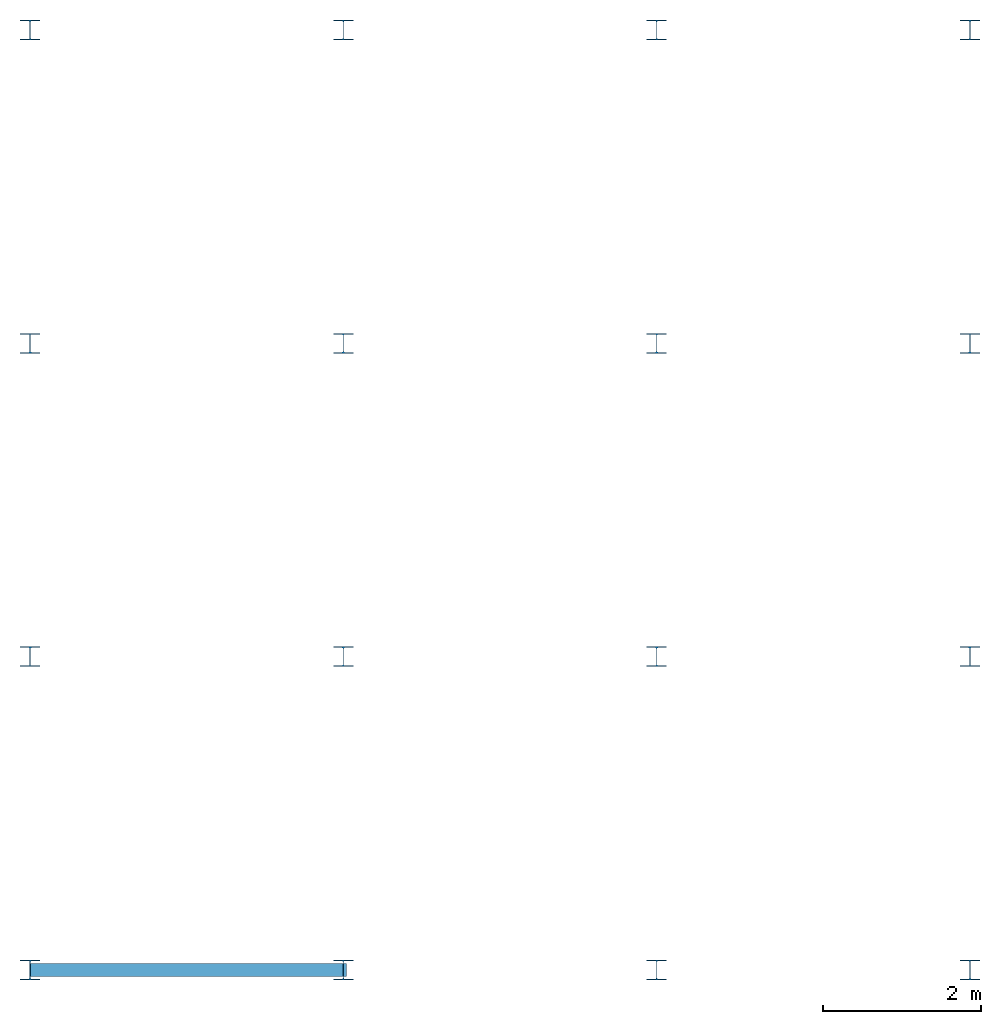
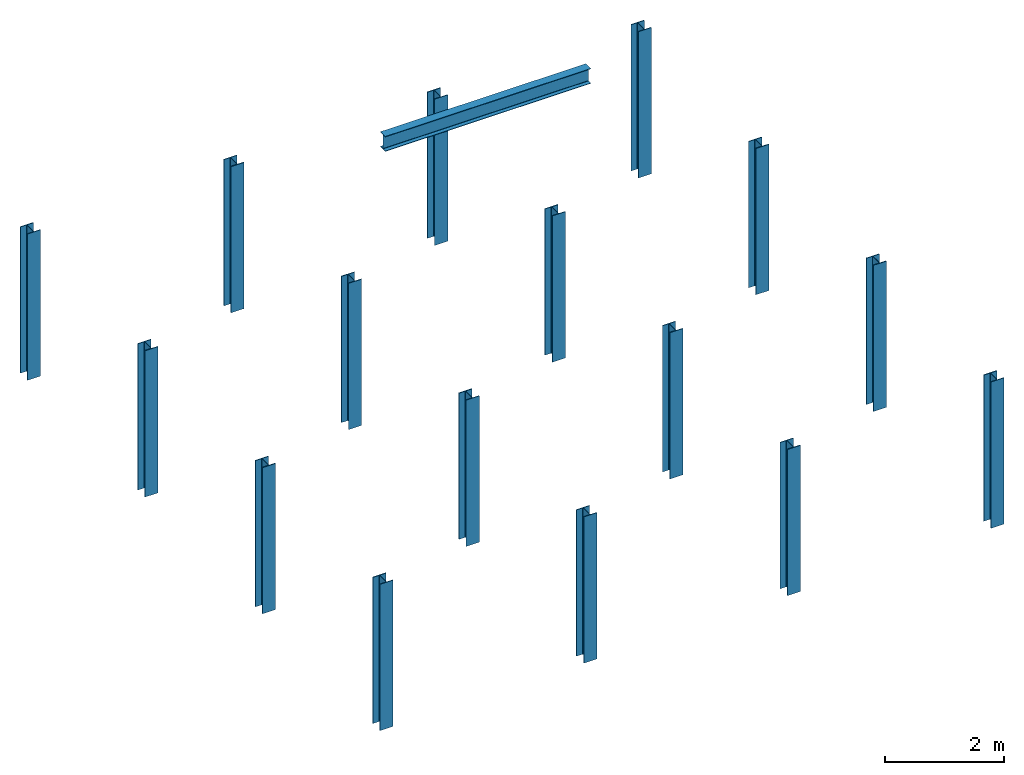
# One storey: 16 columns, 1 beam.
"""IFC4 building model written with IfcOpenShell, lengths in feet."""

from ifc_helpers import new_model, entity, si_unit, converted_unit, derived_unit, direction, frame, origin, origin_2d, place, context, subcontext, project, spatial, line, arc, indexed_curve, i_section, outline, extrude, source, transform, mapped, material, type_object, type_shapes, element, save


model = new_model("IFC4")

# Units and contexts
model_context = context("Model", 3, precision=0.0001, world=origin(), true_north=direction((6.123233995736766e-17, 1.0)))
plan_context = context("Plan", 3, precision=0.0001, world=origin(), true_north=direction((6.123233995736766e-17, 1.0)))
body_context = subcontext(model_context, "Body", "Model", "MODEL_VIEW")
ifc_project = project(units=[converted_unit("LENGTHUNIT", "FOOT", entity("IfcLengthMeasure", 0.3048), si_unit("LENGTHUNIT", "METRE"), dimensions=[1, 0, 0, 0, 0, 0, 0]), converted_unit("AREAUNIT", "SQUARE FOOT", entity("IfcAreaMeasure", 0.09290304), si_unit("AREAUNIT", "SQUARE_METRE"), dimensions=[2, 0, 0, 0, 0, 0, 0]), converted_unit("PLANEANGLEUNIT", "DEGREE", entity("IfcPlaneAngleMeasure", 0.017453292519943278), si_unit("PLANEANGLEUNIT", "RADIAN"), dimensions=[0, 0, 0, 0, 0, 0, 0]), converted_unit("VOLUMEUNIT", "CUBIC FOOT", entity("IfcVolumeMeasure", 0.028316846592000004), si_unit("VOLUMEUNIT", "CUBIC_METRE"), dimensions=[3, 0, 0, 0, 0, 0, 0]), si_unit("PRESSUREUNIT", "PASCAL"), derived_unit("MASSDENSITYUNIT", [(si_unit("MASSUNIT", "GRAM", prefix="KILO"), 1), (si_unit("LENGTHUNIT", "METRE"), -3)]), derived_unit("VAPORPERMEABILITYUNIT", [(si_unit("LENGTHUNIT", "METRE"), -1), (si_unit("TIMEUNIT", "SECOND"), 1)]), derived_unit("USERDEFINED", [(si_unit("MASSUNIT", "GRAM", prefix="KILO"), 1), (si_unit("LENGTHUNIT", "METRE"), 3), (si_unit("TIMEUNIT", "SECOND"), -3), (si_unit("ELECTRICCURRENTUNIT", "AMPERE"), -2)]), derived_unit("MODULUSOFELASTICITYUNIT", [(si_unit("MASSUNIT", "GRAM", prefix="KILO"), 1), (si_unit("LENGTHUNIT", "METRE"), -1), (si_unit("TIMEUNIT", "SECOND"), -2)]), derived_unit("THERMALEXPANSIONCOEFFICIENTUNIT", [(si_unit("THERMODYNAMICTEMPERATUREUNIT", "KELVIN"), -1)]), derived_unit("SPECIFICHEATCAPACITYUNIT", [(si_unit("TIMEUNIT", "SECOND"), -2), (si_unit("THERMODYNAMICTEMPERATUREUNIT", "KELVIN"), -1), (si_unit("LENGTHUNIT", "METRE"), 2)]), derived_unit("THERMALCONDUCTANCEUNIT", [(si_unit("MASSUNIT", "GRAM", prefix="KILO"), 1), (si_unit("TIMEUNIT", "SECOND"), -3), (si_unit("THERMODYNAMICTEMPERATUREUNIT", "KELVIN"), -1), (si_unit("LENGTHUNIT", "METRE"), 1)])], contexts=[model_context, plan_context])

# Site, building, storey
site_placement = place(None, origin())
site = spatial("IfcSite", under=ifc_project, at=site_placement, CompositionType="ELEMENT")
building_placement = place(site_placement, origin())
building = spatial("IfcBuilding", under=site, at=building_placement, CompositionType="ELEMENT")
storey_placement = place(building_placement, origin())
storey = spatial("IfcBuildingStorey", under=building, at=storey_placement, Name="STR 01", CompositionType="ELEMENT", Elevation=0.0)

# Columns
ifc_material = material(Name="Steel ASTM A992", Category="Metal")
column_type = type_object("IfcColumnType", Name="W10X49", PredefinedType="COLUMN", material=ifc_material)
shared_shape = source(origin(), body_context, "Body", "SweptSolid", [
    extrude(outline(indexed_curve([(-0.41666666666666663, -0.4166666666666676), (0.41666666666666663, -0.4166666666666676), (0.41666666666666663, -0.3699999999999996), (0.055833333333333846, -0.3699999999999996), (0.02637055078389421, -0.35779611588277277), (0.014166666666666636, -0.32833333333333287), (0.01416666666666665, 0.32833333333333303), (0.026370550783893467, 0.3577961158827727), (0.05583333333333332, 0.3700000000000003), (0.41666666666666663, 0.3700000000000003), (0.41666666666666663, 0.4166666666666656), (-0.41666666666666663, 0.4166666666666656), (-0.41666666666666663, 0.3700000000000003), (-0.05583333333333365, 0.3700000000000003), (-0.02637055078389416, 0.3577961158827734), (-0.014166666666666685, 0.32833333333333387), (-0.014166666666666685, -0.32833333333333264), (-0.026370550783893578, -0.3577961158827721), (-0.055833333333333374, -0.3699999999999996), (-0.41666666666666663, -0.3699999999999996)], segments=[line(1, 2, 3, 4), arc(4, 5, 6), line(6, 7), arc(7, 8, 9), line(9, 10, 11, 12, 13, 14), arc(14, 15, 16), line(16, 17), arc(17, 18, 19), line(19, 20, 1)], self_intersect=False)), frame((0.0, 0.0, 0.0), z_axis=(0.0, 0.0, 1.0), x_axis=(-1.0, 0.0, 0.0)), (0.0, 0.0, 1.0), 9.875000000001839),
])
type_shapes(column_type, [shared_shape])
for number, where, z_axis, x_axis, name in (
    (1, (0.0, 0.0, 0.0), (0.0, 0.0, 1.0), (-1.0, 0.0, 0.0), "W10X49"),
    (2, (0.0, 13.0, 0.0), (0.0, 0.0, 1.0), (-1.0, 0.0, 0.0), "W10X49"),
    (3, (0.0, 26.0, 0.0), (0.0, 0.0, 1.0), (-1.0, 0.0, 0.0), "W10X49"),
    (4, (0.0, 39.0, 0.0), (0.0, 0.0, 1.0), (-1.0, 0.0, 0.0), "W10X49"),
    (5, (13.0, 13.0, 0.0), (0.0, 0.0, 1.0), (-1.0, 0.0, 0.0), "W10X49"),
    (6, (13.0, 26.0, 0.0), (0.0, 0.0, 1.0), (-1.0, 0.0, 0.0), "W10X49"),
    (7, (13.0, 39.0, 0.0), (0.0, 0.0, 1.0), (-1.0, 0.0, 0.0), "W10X49"),
    (8, (26.0, 0.0, 0.0), (0.0, 0.0, 1.0), (-1.0, 0.0, 0.0), "W10X49"),
    (9, (26.0, 13.0, 0.0), (0.0, 0.0, 1.0), (-1.0, 0.0, 0.0), "W10X49"),
    (10, (26.0, 26.0, 0.0), (0.0, 0.0, 1.0), (-1.0, 0.0, 0.0), "W10X49"),
    (11, (26.0, 39.0, 0.0), (0.0, 0.0, 1.0), (-1.0, 0.0, 0.0), "W10X49"),
    (12, (39.0, 0.0, 0.0), (0.0, 0.0, 1.0), (-1.0, 0.0, 0.0), "W10X49"),
    (13, (39.0, 13.0, 0.0), (0.0, 0.0, 1.0), (-1.0, 0.0, 0.0), "W10X49"),
    (14, (39.0, 26.0, 0.0), (0.0, 0.0, 1.0), (-1.0, 0.0, 0.0), "W10X49"),
    (15, (39.0, 39.0, 0.0), (0.0, 0.0, 1.0), (-1.0, 0.0, 0.0), "W10X49"),
):
    element("IfcColumn", number, at=place(storey_placement, frame(where, z_axis=z_axis, x_axis=x_axis)), inside=storey, type_object=column_type, material=ifc_material, Name=name, ObjectType="W Shapes-Column:W10X49", PredefinedType="COLUMN", context=body_context, shape_type="MappedRepresentation", body=[
        mapped(shared_shape, transform((0.0, 0.0, 0.0), scale=1.0)),
    ])
column_placement = place(storey_placement, frame((13.0, 0.0, 9.875000000003281), z_axis=(0.0, 0.0, 1.0), x_axis=(-1.0, 0.0, 0.0)))
element("IfcColumn", 16, at=column_placement, inside=storey, type_object=column_type, material=ifc_material, Name="W10X49", ObjectType="W10X49", context=model_context, shape_type="SweptSolid", body=[
    extrude(i_section(OverallWidth=0.8333333333333333, OverallDepth=0.8333333333333333, WebThickness=0.02833333333333333, FlangeThickness=0.04666666666666667, FilletRadius=0.041666666666666664, at=origin_2d()), origin(), (0.0, 0.0, -1.0), 9.875000000003281),
])

# Beam
beam_type = type_object("IfcBeamType", Name="W12X26", PredefinedType="BEAM")
beam_placement = place(storey_placement, frame((0.0, 0.0, 39.36666666666666), z_axis=(-1.0, 0.0, 0.0), x_axis=(0.0, -1.0, 0.0)))
element("IfcBeam", 17, at=beam_placement, inside=storey, type_object=beam_type, material=ifc_material, Name="W Shapes:W12X26", ObjectType="W12X26", context=model_context, shape_type="SweptSolid", body=[
    extrude(i_section(OverallWidth=0.5408333333333333, OverallDepth=1.0166666666666666, WebThickness=0.019166666666666665, FlangeThickness=0.03166666666666666, FilletRadius=0.024999999999999998, at=origin_2d()), origin(), (0.0, 0.0, -1.0), 13.123359580052494),
])

save(model, "model.ifc")
